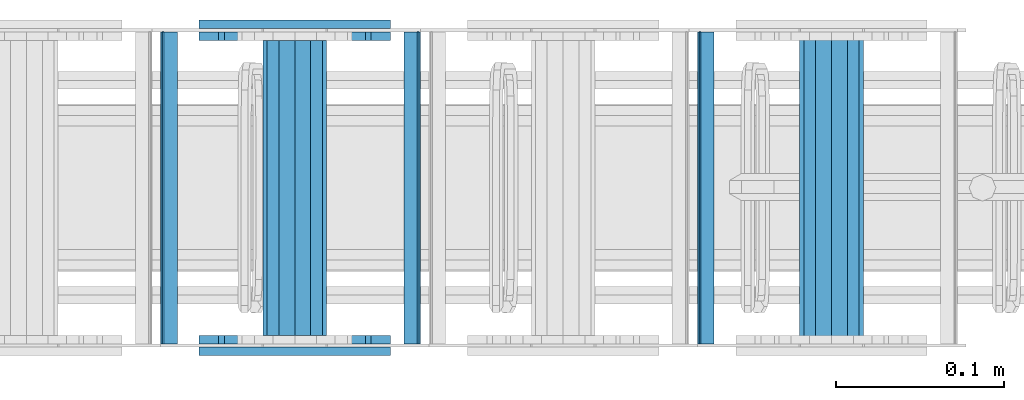
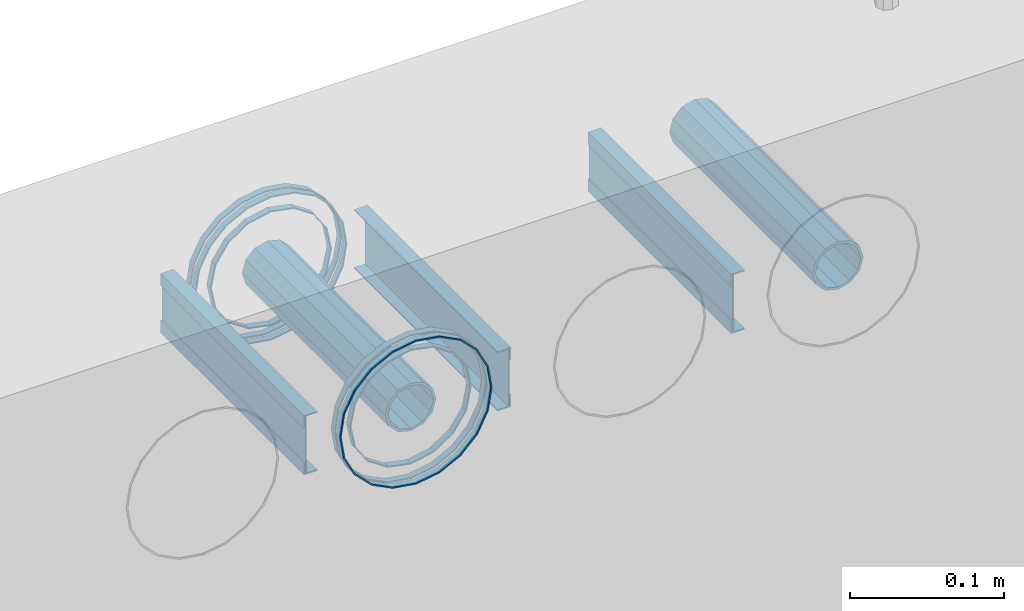
# One storey, part 2 of 11: 17 beams.
"""IFC2X3 building model written with IfcOpenShell, lengths in millimetres."""

import ifcopenshell
import ifcopenshell.guid

model = None  # the IFC model being written
_history = None  # IfcOwnerHistory: only IFC2X3 demands one
_inside = {}  # id of a spatial element -> (the spatial element, [elements in it])
_under = {}  # id of a project, library or spatial element -> (it, [spatial elements below it])
_declared = {}  # id of a project -> (the project, [libraries it declares])
_typed = {}  # id of a type object -> (the type object, [elements of that type])
_made_of = {}  # id of a material, layer set ... -> (it, [elements and type objects made of it])


def new_model(schema):
    """Start an empty IFC model of exactly this schema.

    Asked for "IFC4X3", IfcOpenShell would pick the latest addendum, in which some entities
    have other attributes; the version numbers below select the first issue.
    IFC2X3 requires an IfcOwnerHistory on every rooted entity: one is made here for all.
    """
    global model, _history
    if schema == "IFC4X3":
        model = ifcopenshell.file(schema_version=(4, 3, 0, 0))
    else:
        model = ifcopenshell.file(schema=schema)
    _inside.clear()
    _under.clear()
    _declared.clear()
    _typed.clear()
    _made_of.clear()
    _history = None
    if model.schema == "IFC2X3":
        org = make("IfcOrganization", Name="unknown")
        user = make(
            "IfcPersonAndOrganization",
            ThePerson=make("IfcPerson", FamilyName="unknown"),
            TheOrganization=org,
        )
        app = make(
            "IfcApplication",
            ApplicationDeveloper=org,
            Version="unknown",
            ApplicationFullName="unknown",
            ApplicationIdentifier="unknown",
        )
        _history = make(
            "IfcOwnerHistory",
            OwningUser=user,
            OwningApplication=app,
            ChangeAction="ADDED",
            CreationDate=0,
        )
    return model


def make(cls, **values):
    """One entity of the class cls with the attributes given. An attribute that is None is left unset."""
    return model.create_entity(
        cls, **{name: value for name, value in values.items() if value is not None}
    )


def rooted(cls, **values):
    """An entity with a GlobalId (a new one), such as an element, a storey or a relation."""
    return make(cls, GlobalId=ifcopenshell.guid.new(), OwnerHistory=_history, **values)


def si_unit(unit_type, name, prefix=None):
    """IfcSIUnit, for example si_unit("LENGTHUNIT", "METRE", prefix="MILLI")."""
    return make("IfcSIUnit", UnitType=unit_type, Prefix=prefix, Name=name)


def assignment(units):
    """IfcUnitAssignment: the units of a project."""
    return None if units is None else make("IfcUnitAssignment", Units=units)


def point(xyz):
    """IfcCartesianPoint."""
    return None if xyz is None else make("IfcCartesianPoint", Coordinates=xyz)


def direction(xyz):
    """IfcDirection."""
    return None if xyz is None else make("IfcDirection", DirectionRatios=xyz)


def frame(location, z_axis=None, x_axis=None):
    """IfcAxis2Placement3D, a coordinate frame: its origin and axes. An axis left out is left unset."""
    return make(
        "IfcAxis2Placement3D",
        Location=point(location),
        Axis=direction(z_axis),
        RefDirection=direction(x_axis),
    )


def origin_with_axes():
    """The frame at (0, 0, 0) with the z axis (0, 0, 1) and the x axis (1, 0, 0) written out."""
    return frame((0.0, 0.0, 0.0), z_axis=(0.0, 0.0, 1.0), x_axis=(1.0, 0.0, 0.0))


def place(relative_to, where):
    """IfcLocalPlacement: puts the frame where relative to a parent placement (None: the world)."""
    return make(
        "IfcLocalPlacement", PlacementRelTo=relative_to, RelativePlacement=where
    )


def context(
    kind, dimensions, precision=None, world=None, true_north=None, identifier=None
):
    """IfcGeometricRepresentationContext, for example the 3D "Model" context."""
    return make(
        "IfcGeometricRepresentationContext",
        ContextIdentifier=identifier,
        ContextType=kind,
        CoordinateSpaceDimension=dimensions,
        Precision=precision,
        WorldCoordinateSystem=world,
        TrueNorth=true_north,
    )


def subcontext(parent, identifier, kind, view, scale=None):
    """IfcGeometricRepresentationSubContext, for example "Body" below "Model"."""
    return make(
        "IfcGeometricRepresentationSubContext",
        ContextIdentifier=identifier,
        ContextType=kind,
        ParentContext=parent,
        TargetScale=scale,
        TargetView=view,
    )


def project(units=None, contexts=None):
    """IfcProject with its units and contexts."""
    return rooted(
        "IfcProject",
        Name="project",
        RepresentationContexts=contexts,
        UnitsInContext=assignment(units),
    )


def spatial(cls, under=None, at=None, **own):
    """A site, building, storey or space (cls), placed at a placement, below another one or the project."""
    s = rooted(cls, ObjectPlacement=at, **own)
    if under is not None:
        _under.setdefault(under.id(), (under, []))[1].append(s)
    return s


def faces_of(points, faces, orient=None, outer=None):
    """IfcFace entities. A face is a list of loops; a loop is a list of indices into points, from 0.

    orient and outer hold one flag for each loop. By default every Orientation is true, the
    first loop of a face is its IfcFaceOuterBound and the others are IfcFaceBound.
    """
    made = []
    for i, loops in enumerate(faces):
        bounds = []
        for j, loop in enumerate(loops):
            is_outer = j == 0 if outer is None else outer[i][j]
            bounds.append(
                make(
                    "IfcFaceOuterBound" if is_outer else "IfcFaceBound",
                    Bound=make("IfcPolyLoop", Polygon=[points[k] for k in loop]),
                    Orientation=True if orient is None else orient[i][j],
                )
            )
        made.append(make("IfcFace", Bounds=bounds))
    return made


def faceted_brep(points, faces, orient=None, outer=None, voids=None):
    """IfcFacetedBrep: a solid bounded by flat faces; with voids (closed shells), ...WithVoids."""
    shared = [point(p) for p in points]
    hull = make("IfcClosedShell", CfsFaces=faces_of(shared, faces, orient, outer))
    if voids is None:
        return make("IfcFacetedBrep", Outer=hull)
    return make(
        "IfcFacetedBrepWithVoids",
        Outer=hull,
        Voids=[
            make(cls, CfsFaces=faces_of(shared, fs, o, b)) for cls, fs, o, b in voids
        ],
    )


def shape(context_of_items, identifier, shape_type, items):
    """IfcShapeRepresentation: the items that make up one representation, for example the "Body"."""
    return make(
        "IfcShapeRepresentation",
        ContextOfItems=context_of_items,
        RepresentationIdentifier=identifier,
        RepresentationType=shape_type,
        Items=items,
    )


def material(Name=None, Category=None):
    """IfcMaterial."""
    return make("IfcMaterial", Name=Name, Category=Category)


def made_of(thing, what):
    """Note that an element or type object is made of a material, layer set ...; save() writes the relation."""
    if what is not None:
        _made_of.setdefault(what.id(), (what, []))[1].append(thing)
    return thing


def type_object(cls, material=None, **own):
    """A type object (cls), such as IfcWallType, which elements share."""
    return made_of(rooted(cls, **own), material)


def element(
    cls,
    number,
    at=None,
    inside=None,
    cuts=None,
    type_object=None,
    material=None,
    context=None,
    identifier="Body",
    shape_type=None,
    held_by="IfcProductDefinitionShape",
    body=None,
    shapes=None,
    **own,
):
    """One element of the class cls, such as IfcWall. Its Tag is "e" and its number.

    at: its placement. inside: the storey or other place that contains it. cuts: it is an
    opening in that element (IfcRelVoidsElement). A single representation is given by context,
    identifier, shape_type and body (its items); several are given by shapes. held_by: the class
    of the entity that holds the representations. save() writes the other relations.
    """
    e = rooted(cls, Tag="e%d" % number, ObjectPlacement=at, **own)
    if body is not None:
        shapes = [shape(context, identifier, shape_type, body)]
    if shapes is not None:
        e.Representation = make(held_by, Representations=shapes)
    if inside is not None:
        _inside.setdefault(inside.id(), (inside, []))[1].append(e)
    if cuts is not None:
        rooted(
            "IfcRelVoidsElement", RelatingBuildingElement=cuts, RelatedOpeningElement=e
        )
    if type_object is not None:
        _typed.setdefault(type_object.id(), (type_object, []))[1].append(e)
    return made_of(e, material)


def aggregate(whole, parts):
    """IfcRelAggregates: a whole, such as a stair, and the parts it consists of."""
    return rooted("IfcRelAggregates", RelatingObject=whole, RelatedObjects=parts)


def save(model, path):
    """Write the relations noted so far, then the file.

    IfcRelAggregates (storeys below a building ...), IfcRelContainedInSpatialStructure (elements
    in a storey), IfcRelDefinesByType, IfcRelAssociatesMaterial and IfcRelDeclares: one each for
    every whole, place, type object, material and project.
    """
    for whole, parts in _under.values():
        aggregate(whole, parts)
    for where, things in _inside.values():
        rooted(
            "IfcRelContainedInSpatialStructure",
            RelatedElements=things,
            RelatingStructure=where,
        )
    for kind, things in _typed.values():
        rooted("IfcRelDefinesByType", RelatedObjects=things, RelatingType=kind)
    for what, things in _made_of.values():
        rooted("IfcRelAssociatesMaterial", RelatedObjects=things, RelatingMaterial=what)
    for by, libraries in _declared.values():
        rooted("IfcRelDeclares", RelatingContext=by, RelatedDefinitions=libraries)
    model.write(path)


model = new_model("IFC2X3")

# Units and contexts
model_context = context("Model", 3, precision=1e-05, world=origin_with_axes())
body_context = subcontext(model_context, "Body", "Model", "MODEL_VIEW")
ifc_project = project(units=[si_unit("LENGTHUNIT", "METRE", prefix="MILLI"), si_unit("AREAUNIT", "SQUARE_METRE"), si_unit("VOLUMEUNIT", "CUBIC_METRE"), si_unit("MASSUNIT", "GRAM", prefix="KILO"), si_unit("TIMEUNIT", "SECOND"), si_unit("PLANEANGLEUNIT", "RADIAN"), si_unit("SOLIDANGLEUNIT", "STERADIAN"), si_unit("THERMODYNAMICTEMPERATUREUNIT", "DEGREE_CELSIUS"), si_unit("LUMINOUSINTENSITYUNIT", "LUMEN")], contexts=[model_context])

# Site, building, storey
site_placement = place(None, origin_with_axes())
site = spatial("IfcSite", under=ifc_project, at=site_placement, CompositionType="ELEMENT")
building_placement = place(site_placement, origin_with_axes())
building = spatial("IfcBuilding", under=site, at=building_placement, Name="Undefined", CompositionType="ELEMENT")
storey_placement = place(building_placement, origin_with_axes())
storey = spatial("IfcBuildingStorey", under=building, at=storey_placement, Name="Undefined", CompositionType="ELEMENT", Elevation=0.0)

# Beams
ifc_material = material(Name="STEEL/Steel_Undefined")
beam_type_1 = type_object("IfcBeamType", PredefinedType="NOTDEFINED")
beam_1_placement = place(storey_placement, frame((1659.98457749309, -5.08317012009302, 2335.01381840039), z_axis=(-1.0, 0.0, 0.0), x_axis=(0.0, 1.0, 0.0)))
element("IfcBeam", 1, at=beam_1_placement, inside=storey, type_object=beam_type_1, material=ifc_material, Name="K160", context=body_context, shape_type="Brep", body=[
    faceted_brep([(0.0, -56.0, 0.0), (0.0, -53.2591649125284, 17.3049516849972), (5.0, -53.2591649125284, 17.3049516849972), (5.0, -56.0, 0.0), (0.0, -45.3049516849969, 32.9159741283786), (5.0, -45.3049516849969, 32.9159741283786), (0.0, -32.9159741283784, 45.3049516849972), (5.0, -32.9159741283784, 45.3049516849972), (0.0, -17.3049516849969, 53.2591649125286), (5.0, -17.3049516849969, 53.2591649125286), (0.0, 0.0, 56.0), (5.0, 0.0, 56.0), (0.0, 17.3049516849969, 53.2591649125286), (5.0, 17.3049516849969, 53.2591649125286), (0.0, 32.9159741283784, 45.3049516849972), (5.0, 32.9159741283784, 45.3049516849972), (0.0, 45.3049516849969, 32.9159741283786), (5.0, 45.3049516849969, 32.9159741283786), (0.0, 53.2591649125284, 17.3049516849972), (5.0, 53.2591649125284, 17.3049516849972), (0.0, 56.0, 0.0), (5.0, 56.0, 0.0), (0.0, 53.2591649125284, -17.3049516849972), (5.0, 53.2591649125284, -17.3049516849972), (0.0, 45.3049516849969, -32.9159741283786), (5.0, 45.3049516849969, -32.9159741283786), (0.0, 32.9159741283784, -45.3049516849972), (5.0, 32.9159741283784, -45.3049516849972), (0.0, 17.3049516849969, -53.2591649125286), (5.0, 17.3049516849969, -53.2591649125286), (0.0, 0.0, -56.0), (5.0, 0.0, -56.0), (0.0, -17.3049516849969, -53.2591649125286), (5.0, -17.3049516849969, -53.2591649125286), (0.0, -32.9159741283784, -45.3049516849972), (5.0, -32.9159741283784, -45.3049516849972), (0.0, -45.3049516849969, -32.9159741283786), (5.0, -45.3049516849969, -32.9159741283786), (0.0, -53.2591649125284, -17.3049516849972), (5.0, -53.2591649125284, -17.3049516849972), (0.0, -57.0, 0.0), (0.0, -54.2102214288238, -17.613968679372), (5.0, -54.2102214288238, -17.613968679372), (5.0, -57.0, 0.0), (0.0, -46.1139686793722, -33.503759380671), (5.0, -46.1139686793722, -33.503759380671), (0.0, -33.503759380671, -46.113968679372), (5.0, -33.503759380671, -46.113968679372), (0.0, -17.6139686793722, -54.2102214288238), (5.0, -17.6139686793722, -54.2102214288238), (0.0, 0.0, -57.0), (5.0, 0.0, -57.0), (0.0, 17.6139686793722, -54.2102214288238), (5.0, 17.6139686793722, -54.2102214288238), (0.0, 33.503759380671, -46.113968679372), (5.0, 33.503759380671, -46.113968679372), (0.0, 46.1139686793722, -33.503759380671), (5.0, 46.1139686793722, -33.503759380671), (0.0, 54.2102214288238, -17.613968679372), (5.0, 54.2102214288238, -17.613968679372), (0.0, 57.0, 0.0), (5.0, 57.0, 0.0), (0.0, 54.2102214288238, 17.613968679372), (5.0, 54.2102214288238, 17.613968679372), (0.0, 46.1139686793722, 33.503759380671), (5.0, 46.1139686793722, 33.503759380671), (0.0, 33.503759380671, 46.113968679372), (5.0, 33.503759380671, 46.113968679372), (0.0, 17.6139686793722, 54.2102214288238), (5.0, 17.6139686793722, 54.2102214288238), (0.0, 0.0, 57.0), (5.0, 0.0, 57.0), (0.0, -17.6139686793722, 54.2102214288238), (5.0, -17.6139686793722, 54.2102214288238), (0.0, -33.503759380671, 46.113968679372), (5.0, -33.503759380671, 46.113968679372), (0.0, -46.1139686793722, 33.503759380671), (5.0, -46.1139686793722, 33.503759380671), (0.0, -54.2102214288238, 17.613968679372), (5.0, -54.2102214288238, 17.613968679372)], [[[0, 1, 2, 3]], [[1, 4, 5, 2]], [[4, 6, 7, 5]], [[6, 8, 9, 7]], [[8, 10, 11, 9]], [[10, 12, 13, 11]], [[12, 14, 15, 13]], [[14, 16, 17, 15]], [[16, 18, 19, 17]], [[18, 20, 21, 19]], [[20, 22, 23, 21]], [[22, 24, 25, 23]], [[24, 26, 27, 25]], [[26, 28, 29, 27]], [[28, 30, 31, 29]], [[30, 32, 33, 31]], [[32, 34, 35, 33]], [[34, 36, 37, 35]], [[36, 38, 39, 37]], [[38, 0, 3, 39]], [[40, 41, 42, 43]], [[41, 44, 45, 42]], [[44, 46, 47, 45]], [[46, 48, 49, 47]], [[48, 50, 51, 49]], [[50, 52, 53, 51]], [[52, 54, 55, 53]], [[54, 56, 57, 55]], [[56, 58, 59, 57]], [[58, 60, 61, 59]], [[60, 62, 63, 61]], [[62, 64, 65, 63]], [[64, 66, 67, 65]], [[66, 68, 69, 67]], [[68, 70, 71, 69]], [[70, 72, 73, 71]], [[72, 74, 75, 73]], [[74, 76, 77, 75]], [[76, 78, 79, 77]], [[78, 40, 43, 79]], [[45, 47, 49, 51, 53, 55, 57, 59, 61, 63, 65, 67, 69, 71, 73, 75, 77, 79, 43, 42], [5, 7, 9, 11, 13, 15, 17, 19, 21, 23, 25, 27, 29, 31, 33, 35, 37, 39, 3, 2]], [[78, 76, 74, 72, 70, 68, 66, 64, 62, 60, 58, 56, 54, 52, 50, 48, 46, 44, 41, 40], [38, 36, 34, 32, 30, 28, 26, 24, 22, 20, 18, 16, 14, 12, 10, 8, 6, 4, 1, 0]]]),
])
beam_2_placement = place(storey_placement, frame((1659.98457749309, -200.083170120093, 2335.01381840039), z_axis=(-1.0, 0.0, 0.0), x_axis=(0.0, 1.0, 0.0)))
element("IfcBeam", 2, at=beam_2_placement, inside=storey, type_object=beam_type_1, material=ifc_material, context=body_context, shape_type="Brep", body=[
    faceted_brep([(0.0, -56.0, 0.0), (0.0, -53.2591649125284, 17.3049516849972), (5.0, -53.2591649125284, 17.3049516849972), (5.0, -56.0, 0.0), (0.0, -45.3049516849969, 32.9159741283786), (5.0, -45.3049516849969, 32.9159741283786), (0.0, -32.9159741283784, 45.3049516849972), (5.0, -32.9159741283784, 45.3049516849972), (0.0, -17.3049516849969, 53.2591649125286), (5.0, -17.3049516849969, 53.2591649125286), (0.0, 0.0, 56.0), (5.0, 0.0, 56.0), (0.0, 17.3049516849969, 53.2591649125286), (5.0, 17.3049516849969, 53.2591649125286), (0.0, 32.9159741283784, 45.3049516849972), (5.0, 32.9159741283784, 45.3049516849972), (0.0, 45.3049516849969, 32.9159741283786), (5.0, 45.3049516849969, 32.9159741283786), (0.0, 53.2591649125284, 17.3049516849972), (5.0, 53.2591649125284, 17.3049516849972), (0.0, 56.0, 0.0), (5.0, 56.0, 0.0), (0.0, 53.2591649125284, -17.3049516849972), (5.0, 53.2591649125284, -17.3049516849972), (0.0, 45.3049516849969, -32.9159741283786), (5.0, 45.3049516849969, -32.9159741283786), (0.0, 32.9159741283784, -45.3049516849972), (5.0, 32.9159741283784, -45.3049516849972), (0.0, 17.3049516849969, -53.2591649125286), (5.0, 17.3049516849969, -53.2591649125286), (0.0, 0.0, -56.0), (5.0, 0.0, -56.0), (0.0, -17.3049516849969, -53.2591649125286), (5.0, -17.3049516849969, -53.2591649125286), (0.0, -32.9159741283784, -45.3049516849972), (5.0, -32.9159741283784, -45.3049516849972), (0.0, -45.3049516849969, -32.9159741283786), (5.0, -45.3049516849969, -32.9159741283786), (0.0, -53.2591649125284, -17.3049516849972), (5.0, -53.2591649125284, -17.3049516849972), (0.0, -57.0, 0.0), (0.0, -54.2102214288238, -17.613968679372), (5.0, -54.2102214288238, -17.613968679372), (5.0, -57.0, 0.0), (0.0, -46.1139686793722, -33.503759380671), (5.0, -46.1139686793722, -33.503759380671), (0.0, -33.503759380671, -46.113968679372), (5.0, -33.503759380671, -46.113968679372), (0.0, -17.6139686793722, -54.2102214288238), (5.0, -17.6139686793722, -54.2102214288238), (0.0, 0.0, -57.0), (5.0, 0.0, -57.0), (0.0, 17.6139686793722, -54.2102214288238), (5.0, 17.6139686793722, -54.2102214288238), (0.0, 33.503759380671, -46.113968679372), (5.0, 33.503759380671, -46.113968679372), (0.0, 46.1139686793722, -33.503759380671), (5.0, 46.1139686793722, -33.503759380671), (0.0, 54.2102214288238, -17.613968679372), (5.0, 54.2102214288238, -17.613968679372), (0.0, 57.0, 0.0), (5.0, 57.0, 0.0), (0.0, 54.2102214288238, 17.613968679372), (5.0, 54.2102214288238, 17.613968679372), (0.0, 46.1139686793722, 33.503759380671), (5.0, 46.1139686793722, 33.503759380671), (0.0, 33.503759380671, 46.113968679372), (5.0, 33.503759380671, 46.113968679372), (0.0, 17.6139686793722, 54.2102214288238), (5.0, 17.6139686793722, 54.2102214288238), (0.0, 0.0, 57.0), (5.0, 0.0, 57.0), (0.0, -17.6139686793722, 54.2102214288238), (5.0, -17.6139686793722, 54.2102214288238), (0.0, -33.503759380671, 46.113968679372), (5.0, -33.503759380671, 46.113968679372), (0.0, -46.1139686793722, 33.503759380671), (5.0, -46.1139686793722, 33.503759380671), (0.0, -54.2102214288238, 17.613968679372), (5.0, -54.2102214288238, 17.613968679372)], [[[0, 1, 2, 3]], [[1, 4, 5, 2]], [[4, 6, 7, 5]], [[6, 8, 9, 7]], [[8, 10, 11, 9]], [[10, 12, 13, 11]], [[12, 14, 15, 13]], [[14, 16, 17, 15]], [[16, 18, 19, 17]], [[18, 20, 21, 19]], [[20, 22, 23, 21]], [[22, 24, 25, 23]], [[24, 26, 27, 25]], [[26, 28, 29, 27]], [[28, 30, 31, 29]], [[30, 32, 33, 31]], [[32, 34, 35, 33]], [[34, 36, 37, 35]], [[36, 38, 39, 37]], [[38, 0, 3, 39]], [[40, 41, 42, 43]], [[41, 44, 45, 42]], [[44, 46, 47, 45]], [[46, 48, 49, 47]], [[48, 50, 51, 49]], [[50, 52, 53, 51]], [[52, 54, 55, 53]], [[54, 56, 57, 55]], [[56, 58, 59, 57]], [[58, 60, 61, 59]], [[60, 62, 63, 61]], [[62, 64, 65, 63]], [[64, 66, 67, 65]], [[66, 68, 69, 67]], [[68, 70, 71, 69]], [[70, 72, 73, 71]], [[72, 74, 75, 73]], [[74, 76, 77, 75]], [[76, 78, 79, 77]], [[78, 40, 43, 79]], [[45, 47, 49, 51, 53, 55, 57, 59, 61, 63, 65, 67, 69, 71, 73, 75, 77, 79, 43, 42], [5, 7, 9, 11, 13, 15, 17, 19, 21, 23, 25, 27, 29, 31, 33, 35, 37, 39, 3, 2]], [[78, 76, 74, 72, 70, 68, 66, 64, 62, 60, 58, 56, 54, 52, 50, 48, 46, 44, 41, 40], [38, 36, 34, 32, 30, 28, 26, 24, 22, 20, 18, 16, 14, 12, 10, 8, 6, 4, 1, 0]]]),
])
beam_3_placement = place(storey_placement, frame((1659.98457749309, -12.083170120093, 2335.01381840039), z_axis=(-1.0, 0.0, 0.0), x_axis=(0.0, 1.0, 0.0)))
element("IfcBeam", 3, at=beam_3_placement, inside=storey, type_object=beam_type_1, material=ifc_material, context=body_context, shape_type="Brep", body=[
    faceted_brep([(0.0, -56.0, 0.0), (0.0, -53.2591649125284, 17.3049516849972), (5.0, -53.2591649125284, 17.3049516849972), (5.0, -56.0, 0.0), (0.0, -45.3049516849969, 32.9159741283786), (5.0, -45.3049516849969, 32.9159741283786), (0.0, -32.9159741283784, 45.3049516849972), (5.0, -32.9159741283784, 45.3049516849972), (0.0, -17.3049516849969, 53.2591649125286), (5.0, -17.3049516849969, 53.2591649125286), (0.0, 0.0, 56.0), (5.0, 0.0, 56.0), (0.0, 17.3049516849969, 53.2591649125286), (5.0, 17.3049516849969, 53.2591649125286), (0.0, 32.9159741283784, 45.3049516849972), (5.0, 32.9159741283784, 45.3049516849972), (0.0, 45.3049516849969, 32.9159741283786), (5.0, 45.3049516849969, 32.9159741283786), (0.0, 53.2591649125284, 17.3049516849972), (5.0, 53.2591649125284, 17.3049516849972), (0.0, 56.0, 0.0), (5.0, 56.0, 0.0), (0.0, 53.2591649125284, -17.3049516849972), (5.0, 53.2591649125284, -17.3049516849972), (0.0, 45.3049516849969, -32.9159741283786), (5.0, 45.3049516849969, -32.9159741283786), (0.0, 32.9159741283784, -45.3049516849972), (5.0, 32.9159741283784, -45.3049516849972), (0.0, 17.3049516849969, -53.2591649125286), (5.0, 17.3049516849969, -53.2591649125286), (0.0, 0.0, -56.0), (5.0, 0.0, -56.0), (0.0, -17.3049516849969, -53.2591649125286), (5.0, -17.3049516849969, -53.2591649125286), (0.0, -32.9159741283784, -45.3049516849972), (5.0, -32.9159741283784, -45.3049516849972), (0.0, -45.3049516849969, -32.9159741283786), (5.0, -45.3049516849969, -32.9159741283786), (0.0, -53.2591649125284, -17.3049516849972), (5.0, -53.2591649125284, -17.3049516849972), (0.0, -57.0, 0.0), (0.0, -54.2102214288238, -17.613968679372), (5.0, -54.2102214288238, -17.613968679372), (5.0, -57.0, 0.0), (0.0, -46.1139686793722, -33.503759380671), (5.0, -46.1139686793722, -33.503759380671), (0.0, -33.503759380671, -46.113968679372), (5.0, -33.503759380671, -46.113968679372), (0.0, -17.6139686793722, -54.2102214288238), (5.0, -17.6139686793722, -54.2102214288238), (0.0, 0.0, -57.0), (5.0, 0.0, -57.0), (0.0, 17.6139686793722, -54.2102214288238), (5.0, 17.6139686793722, -54.2102214288238), (0.0, 33.503759380671, -46.113968679372), (5.0, 33.503759380671, -46.113968679372), (0.0, 46.1139686793722, -33.503759380671), (5.0, 46.1139686793722, -33.503759380671), (0.0, 54.2102214288238, -17.613968679372), (5.0, 54.2102214288238, -17.613968679372), (0.0, 57.0, 0.0), (5.0, 57.0, 0.0), (0.0, 54.2102214288238, 17.613968679372), (5.0, 54.2102214288238, 17.613968679372), (0.0, 46.1139686793722, 33.503759380671), (5.0, 46.1139686793722, 33.503759380671), (0.0, 33.503759380671, 46.113968679372), (5.0, 33.503759380671, 46.113968679372), (0.0, 17.6139686793722, 54.2102214288238), (5.0, 17.6139686793722, 54.2102214288238), (0.0, 0.0, 57.0), (5.0, 0.0, 57.0), (0.0, -17.6139686793722, 54.2102214288238), (5.0, -17.6139686793722, 54.2102214288238), (0.0, -33.503759380671, 46.113968679372), (5.0, -33.503759380671, 46.113968679372), (0.0, -46.1139686793722, 33.503759380671), (5.0, -46.1139686793722, 33.503759380671), (0.0, -54.2102214288238, 17.613968679372), (5.0, -54.2102214288238, 17.613968679372)], [[[0, 1, 2, 3]], [[1, 4, 5, 2]], [[4, 6, 7, 5]], [[6, 8, 9, 7]], [[8, 10, 11, 9]], [[10, 12, 13, 11]], [[12, 14, 15, 13]], [[14, 16, 17, 15]], [[16, 18, 19, 17]], [[18, 20, 21, 19]], [[20, 22, 23, 21]], [[22, 24, 25, 23]], [[24, 26, 27, 25]], [[26, 28, 29, 27]], [[28, 30, 31, 29]], [[30, 32, 33, 31]], [[32, 34, 35, 33]], [[34, 36, 37, 35]], [[36, 38, 39, 37]], [[38, 0, 3, 39]], [[40, 41, 42, 43]], [[41, 44, 45, 42]], [[44, 46, 47, 45]], [[46, 48, 49, 47]], [[48, 50, 51, 49]], [[50, 52, 53, 51]], [[52, 54, 55, 53]], [[54, 56, 57, 55]], [[56, 58, 59, 57]], [[58, 60, 61, 59]], [[60, 62, 63, 61]], [[62, 64, 65, 63]], [[64, 66, 67, 65]], [[66, 68, 69, 67]], [[68, 70, 71, 69]], [[70, 72, 73, 71]], [[72, 74, 75, 73]], [[74, 76, 77, 75]], [[76, 78, 79, 77]], [[78, 40, 43, 79]], [[45, 47, 49, 51, 53, 55, 57, 59, 61, 63, 65, 67, 69, 71, 73, 75, 77, 79, 43, 42], [5, 7, 9, 11, 13, 15, 17, 19, 21, 23, 25, 27, 29, 31, 33, 35, 37, 39, 3, 2]], [[78, 76, 74, 72, 70, 68, 66, 64, 62, 60, 58, 56, 54, 52, 50, 48, 46, 44, 41, 40], [38, 36, 34, 32, 30, 28, 26, 24, 22, 20, 18, 16, 14, 12, 10, 8, 6, 4, 1, 0]]]),
])
beam_4_placement = place(storey_placement, frame((1659.98457749309, -188.083170120093, 2335.01381840039), z_axis=(-1.0, 0.0, 0.0), x_axis=(0.0, -1.0, 0.0)))
element("IfcBeam", 4, at=beam_4_placement, inside=storey, type_object=beam_type_1, material=ifc_material, context=body_context, shape_type="Brep", body=[
    faceted_brep([(0.0, -56.0, 0.0), (0.0, -53.2591649125284, 17.3049516849972), (5.0, -53.2591649125284, 17.3049516849972), (5.0, -56.0, 0.0), (0.0, -45.3049516849969, 32.9159741283786), (5.0, -45.3049516849969, 32.9159741283786), (0.0, -32.9159741283784, 45.3049516849972), (5.0, -32.9159741283784, 45.3049516849972), (0.0, -17.3049516849969, 53.2591649125286), (5.0, -17.3049516849969, 53.2591649125286), (0.0, 0.0, 56.0), (5.0, 0.0, 56.0), (0.0, 17.3049516849969, 53.2591649125286), (5.0, 17.3049516849969, 53.2591649125286), (0.0, 32.9159741283784, 45.3049516849972), (5.0, 32.9159741283784, 45.3049516849972), (0.0, 45.3049516849969, 32.9159741283786), (5.0, 45.3049516849969, 32.9159741283786), (0.0, 53.2591649125284, 17.3049516849972), (5.0, 53.2591649125284, 17.3049516849972), (0.0, 56.0, 0.0), (5.0, 56.0, 0.0), (0.0, 53.2591649125284, -17.3049516849972), (5.0, 53.2591649125284, -17.3049516849972), (0.0, 45.3049516849969, -32.9159741283786), (5.0, 45.3049516849969, -32.9159741283786), (0.0, 32.9159741283784, -45.3049516849972), (5.0, 32.9159741283784, -45.3049516849972), (0.0, 17.3049516849969, -53.2591649125286), (5.0, 17.3049516849969, -53.2591649125286), (0.0, 0.0, -56.0), (5.0, 0.0, -56.0), (0.0, -17.3049516849969, -53.2591649125286), (5.0, -17.3049516849969, -53.2591649125286), (0.0, -32.9159741283784, -45.3049516849972), (5.0, -32.9159741283784, -45.3049516849972), (0.0, -45.3049516849969, -32.9159741283786), (5.0, -45.3049516849969, -32.9159741283786), (0.0, -53.2591649125284, -17.3049516849972), (5.0, -53.2591649125284, -17.3049516849972), (0.0, -57.0, 0.0), (0.0, -54.2102214288238, -17.613968679372), (5.0, -54.2102214288238, -17.613968679372), (5.0, -57.0, 0.0), (0.0, -46.1139686793722, -33.503759380671), (5.0, -46.1139686793722, -33.503759380671), (0.0, -33.503759380671, -46.113968679372), (5.0, -33.503759380671, -46.113968679372), (0.0, -17.6139686793722, -54.2102214288238), (5.0, -17.6139686793722, -54.2102214288238), (0.0, 0.0, -57.0), (5.0, 0.0, -57.0), (0.0, 17.6139686793722, -54.2102214288238), (5.0, 17.6139686793722, -54.2102214288238), (0.0, 33.503759380671, -46.113968679372), (5.0, 33.503759380671, -46.113968679372), (0.0, 46.1139686793722, -33.503759380671), (5.0, 46.1139686793722, -33.503759380671), (0.0, 54.2102214288238, -17.613968679372), (5.0, 54.2102214288238, -17.613968679372), (0.0, 57.0, 0.0), (5.0, 57.0, 0.0), (0.0, 54.2102214288238, 17.613968679372), (5.0, 54.2102214288238, 17.613968679372), (0.0, 46.1139686793722, 33.503759380671), (5.0, 46.1139686793722, 33.503759380671), (0.0, 33.503759380671, 46.113968679372), (5.0, 33.503759380671, 46.113968679372), (0.0, 17.6139686793722, 54.2102214288238), (5.0, 17.6139686793722, 54.2102214288238), (0.0, 0.0, 57.0), (5.0, 0.0, 57.0), (0.0, -17.6139686793722, 54.2102214288238), (5.0, -17.6139686793722, 54.2102214288238), (0.0, -33.503759380671, 46.113968679372), (5.0, -33.503759380671, 46.113968679372), (0.0, -46.1139686793722, 33.503759380671), (5.0, -46.1139686793722, 33.503759380671), (0.0, -54.2102214288238, 17.613968679372), (5.0, -54.2102214288238, 17.613968679372)], [[[0, 1, 2, 3]], [[1, 4, 5, 2]], [[4, 6, 7, 5]], [[6, 8, 9, 7]], [[8, 10, 11, 9]], [[10, 12, 13, 11]], [[12, 14, 15, 13]], [[14, 16, 17, 15]], [[16, 18, 19, 17]], [[18, 20, 21, 19]], [[20, 22, 23, 21]], [[22, 24, 25, 23]], [[24, 26, 27, 25]], [[26, 28, 29, 27]], [[28, 30, 31, 29]], [[30, 32, 33, 31]], [[32, 34, 35, 33]], [[34, 36, 37, 35]], [[36, 38, 39, 37]], [[38, 0, 3, 39]], [[40, 41, 42, 43]], [[41, 44, 45, 42]], [[44, 46, 47, 45]], [[46, 48, 49, 47]], [[48, 50, 51, 49]], [[50, 52, 53, 51]], [[52, 54, 55, 53]], [[54, 56, 57, 55]], [[56, 58, 59, 57]], [[58, 60, 61, 59]], [[60, 62, 63, 61]], [[62, 64, 65, 63]], [[64, 66, 67, 65]], [[66, 68, 69, 67]], [[68, 70, 71, 69]], [[70, 72, 73, 71]], [[72, 74, 75, 73]], [[74, 76, 77, 75]], [[76, 78, 79, 77]], [[78, 40, 43, 79]], [[45, 47, 49, 51, 53, 55, 57, 59, 61, 63, 65, 67, 69, 71, 73, 75, 77, 79, 43, 42], [5, 7, 9, 11, 13, 15, 17, 19, 21, 23, 25, 27, 29, 31, 33, 35, 37, 39, 3, 2]], [[78, 76, 74, 72, 70, 68, 66, 64, 62, 60, 58, 56, 54, 52, 50, 48, 46, 44, 41, 40], [38, 36, 34, 32, 30, 28, 26, 24, 22, 20, 18, 16, 14, 12, 10, 8, 6, 4, 1, 0]]]),
])
beam_type_2 = type_object("IfcBeamType", PredefinedType="NOTDEFINED")
beam_5_placement = place(storey_placement, frame((1659.98457749309, -12.083170120093, 2335.01381840039), z_axis=(-1.0, 0.0, 0.0), x_axis=(0.0, 1.0, 0.0)))
element("IfcBeam", 5, at=beam_5_placement, inside=storey, type_object=beam_type_2, material=ifc_material, context=body_context, shape_type="Brep", body=[
    faceted_brep([(0.0, -44.5, 0.0), (0.0, -41.1126391967523, 17.0294127402465), (5.0, -41.1126391967523, 17.0294127402465), (5.0, -44.5, 0.0), (0.0, -31.4662517628012, 31.4662517628014), (5.0, -31.4662517628012, 31.4662517628014), (0.0, -17.0294127402467, 41.1126391967523), (5.0, -17.0294127402467, 41.1126391967523), (0.0, 0.0, 44.5), (5.0, 0.0, 44.5), (0.0, 17.0294127402467, 41.1126391967523), (5.0, 17.0294127402467, 41.1126391967523), (0.0, 31.4662517628012, 31.4662517628014), (5.0, 31.4662517628012, 31.4662517628014), (0.0, 41.1126391967523, 17.0294127402465), (5.0, 41.1126391967523, 17.0294127402465), (0.0, 44.5, 0.0), (5.0, 44.5, 0.0), (0.0, 41.1126391967523, -17.0294127402465), (5.0, 41.1126391967523, -17.0294127402465), (0.0, 31.4662517628012, -31.4662517628014), (5.0, 31.4662517628012, -31.4662517628014), (0.0, 17.0294127402467, -41.1126391967523), (5.0, 17.0294127402467, -41.1126391967523), (0.0, 0.0, -44.5), (5.0, 0.0, -44.5), (0.0, -17.0294127402467, -41.1126391967523), (5.0, -17.0294127402467, -41.1126391967523), (0.0, -31.4662517628012, -31.4662517628014), (5.0, -31.4662517628012, -31.4662517628014), (0.0, -41.1126391967523, -17.0294127402465), (5.0, -41.1126391967523, -17.0294127402465), (0.0, -45.5, 0.0), (0.0, -42.0365187292637, -17.4120961726117), (5.0, -42.0365187292637, -17.4120961726117), (5.0, -45.5, 0.0), (0.0, -32.1733585439879, -32.1733585439879), (5.0, -32.1733585439879, -32.1733585439879), (0.0, -17.4120961726117, -42.0365187292634), (5.0, -17.4120961726117, -42.0365187292634), (0.0, 0.0, -45.5), (5.0, 0.0, -45.5), (0.0, 17.4120961726117, -42.0365187292634), (5.0, 17.4120961726117, -42.0365187292634), (0.0, 32.1733585439879, -32.1733585439879), (5.0, 32.1733585439879, -32.1733585439879), (0.0, 42.0365187292637, -17.4120961726117), (5.0, 42.0365187292637, -17.4120961726117), (0.0, 45.5, 0.0), (5.0, 45.5, 0.0), (0.0, 42.0365187292637, 17.4120961726117), (5.0, 42.0365187292637, 17.4120961726117), (0.0, 32.1733585439879, 32.1733585439879), (5.0, 32.1733585439879, 32.1733585439879), (0.0, 17.4120961726117, 42.0365187292634), (5.0, 17.4120961726117, 42.0365187292634), (0.0, 0.0, 45.5), (5.0, 0.0, 45.5), (0.0, -17.4120961726117, 42.0365187292634), (5.0, -17.4120961726117, 42.0365187292634), (0.0, -32.1733585439879, 32.1733585439879), (5.0, -32.1733585439879, 32.1733585439879), (0.0, -42.0365187292637, 17.4120961726117), (5.0, -42.0365187292637, 17.4120961726117)], [[[0, 1, 2, 3]], [[1, 4, 5, 2]], [[4, 6, 7, 5]], [[6, 8, 9, 7]], [[8, 10, 11, 9]], [[10, 12, 13, 11]], [[12, 14, 15, 13]], [[14, 16, 17, 15]], [[16, 18, 19, 17]], [[18, 20, 21, 19]], [[20, 22, 23, 21]], [[22, 24, 25, 23]], [[24, 26, 27, 25]], [[26, 28, 29, 27]], [[28, 30, 31, 29]], [[30, 0, 3, 31]], [[32, 33, 34, 35]], [[33, 36, 37, 34]], [[36, 38, 39, 37]], [[38, 40, 41, 39]], [[40, 42, 43, 41]], [[42, 44, 45, 43]], [[44, 46, 47, 45]], [[46, 48, 49, 47]], [[48, 50, 51, 49]], [[50, 52, 53, 51]], [[52, 54, 55, 53]], [[54, 56, 57, 55]], [[56, 58, 59, 57]], [[58, 60, 61, 59]], [[60, 62, 63, 61]], [[62, 32, 35, 63]], [[37, 39, 41, 43, 45, 47, 49, 51, 53, 55, 57, 59, 61, 63, 35, 34], [5, 7, 9, 11, 13, 15, 17, 19, 21, 23, 25, 27, 29, 31, 3, 2]], [[62, 60, 58, 56, 54, 52, 50, 48, 46, 44, 42, 40, 38, 36, 33, 32], [30, 28, 26, 24, 22, 20, 18, 16, 14, 12, 10, 8, 6, 4, 1, 0]]]),
])
beam_6_placement = place(storey_placement, frame((1659.98457749309, -188.083170120093, 2335.01381840039), z_axis=(-1.0, 0.0, 0.0), x_axis=(0.0, -1.0, 0.0)))
element("IfcBeam", 6, at=beam_6_placement, inside=storey, type_object=beam_type_2, material=ifc_material, context=body_context, shape_type="Brep", body=[
    faceted_brep([(0.0, -44.5, 0.0), (0.0, -41.1126391967523, 17.0294127402465), (5.0, -41.1126391967523, 17.0294127402465), (5.0, -44.5, 0.0), (0.0, -31.4662517628012, 31.4662517628014), (5.0, -31.4662517628012, 31.4662517628014), (0.0, -17.0294127402467, 41.1126391967523), (5.0, -17.0294127402467, 41.1126391967523), (0.0, 0.0, 44.5), (5.0, 0.0, 44.5), (0.0, 17.0294127402467, 41.1126391967523), (5.0, 17.0294127402467, 41.1126391967523), (0.0, 31.4662517628012, 31.4662517628014), (5.0, 31.4662517628012, 31.4662517628014), (0.0, 41.1126391967523, 17.0294127402465), (5.0, 41.1126391967523, 17.0294127402465), (0.0, 44.5, 0.0), (5.0, 44.5, 0.0), (0.0, 41.1126391967523, -17.0294127402465), (5.0, 41.1126391967523, -17.0294127402465), (0.0, 31.4662517628012, -31.4662517628014), (5.0, 31.4662517628012, -31.4662517628014), (0.0, 17.0294127402467, -41.1126391967523), (5.0, 17.0294127402467, -41.1126391967523), (0.0, 0.0, -44.5), (5.0, 0.0, -44.5), (0.0, -17.0294127402467, -41.1126391967523), (5.0, -17.0294127402467, -41.1126391967523), (0.0, -31.4662517628012, -31.4662517628014), (5.0, -31.4662517628012, -31.4662517628014), (0.0, -41.1126391967523, -17.0294127402465), (5.0, -41.1126391967523, -17.0294127402465), (0.0, -45.5, 0.0), (0.0, -42.0365187292637, -17.4120961726117), (5.0, -42.0365187292637, -17.4120961726117), (5.0, -45.5, 0.0), (0.0, -32.1733585439879, -32.1733585439879), (5.0, -32.1733585439879, -32.1733585439879), (0.0, -17.4120961726117, -42.0365187292634), (5.0, -17.4120961726117, -42.0365187292634), (0.0, 0.0, -45.5), (5.0, 0.0, -45.5), (0.0, 17.4120961726117, -42.0365187292634), (5.0, 17.4120961726117, -42.0365187292634), (0.0, 32.1733585439879, -32.1733585439879), (5.0, 32.1733585439879, -32.1733585439879), (0.0, 42.0365187292637, -17.4120961726117), (5.0, 42.0365187292637, -17.4120961726117), (0.0, 45.5, 0.0), (5.0, 45.5, 0.0), (0.0, 42.0365187292637, 17.4120961726117), (5.0, 42.0365187292637, 17.4120961726117), (0.0, 32.1733585439879, 32.1733585439879), (5.0, 32.1733585439879, 32.1733585439879), (0.0, 17.4120961726117, 42.0365187292634), (5.0, 17.4120961726117, 42.0365187292634), (0.0, 0.0, 45.5), (5.0, 0.0, 45.5), (0.0, -17.4120961726117, 42.0365187292634), (5.0, -17.4120961726117, 42.0365187292634), (0.0, -32.1733585439879, 32.1733585439879), (5.0, -32.1733585439879, 32.1733585439879), (0.0, -42.0365187292637, 17.4120961726117), (5.0, -42.0365187292637, 17.4120961726117)], [[[0, 1, 2, 3]], [[1, 4, 5, 2]], [[4, 6, 7, 5]], [[6, 8, 9, 7]], [[8, 10, 11, 9]], [[10, 12, 13, 11]], [[12, 14, 15, 13]], [[14, 16, 17, 15]], [[16, 18, 19, 17]], [[18, 20, 21, 19]], [[20, 22, 23, 21]], [[22, 24, 25, 23]], [[24, 26, 27, 25]], [[26, 28, 29, 27]], [[28, 30, 31, 29]], [[30, 0, 3, 31]], [[32, 33, 34, 35]], [[33, 36, 37, 34]], [[36, 38, 39, 37]], [[38, 40, 41, 39]], [[40, 42, 43, 41]], [[42, 44, 45, 43]], [[44, 46, 47, 45]], [[46, 48, 49, 47]], [[48, 50, 51, 49]], [[50, 52, 53, 51]], [[52, 54, 55, 53]], [[54, 56, 57, 55]], [[56, 58, 59, 57]], [[58, 60, 61, 59]], [[60, 62, 63, 61]], [[62, 32, 35, 63]], [[37, 39, 41, 43, 45, 47, 49, 51, 53, 55, 57, 59, 61, 63, 35, 34], [5, 7, 9, 11, 13, 15, 17, 19, 21, 23, 25, 27, 29, 31, 3, 2]], [[62, 60, 58, 56, 54, 52, 50, 48, 46, 44, 42, 40, 38, 36, 33, 32], [30, 28, 26, 24, 22, 20, 18, 16, 14, 12, 10, 8, 6, 4, 1, 0]]]),
])
beam_type_3 = type_object("IfcBeamType", PredefinedType="NOTDEFINED")
beam_7_placement = place(storey_placement, frame((1979.98457749309, -193.083170120093, 2335.01381840039), z_axis=(-1.0, 0.0, 0.0), x_axis=(0.0, 1.0, 0.0)))
element("IfcBeam", 7, at=beam_7_placement, inside=storey, type_object=beam_type_3, material=ifc_material, context=body_context, shape_type="Brep", body=[
    faceted_brep([(0.0, -17.0, 0.0), (0.0, -14.7224318643352, 8.5), (186.0, -14.7224318643352, 8.5), (186.0, -17.0, 0.0), (0.0, -8.5, 14.7224318643355), (186.0, -8.5, 14.7224318643355), (0.0, 0.0, 17.0), (186.0, 0.0, 17.0), (0.0, 8.5, 14.7224318643355), (186.0, 8.5, 14.7224318643355), (0.0, 14.7224318643352, 8.5), (186.0, 14.7224318643352, 8.5), (0.0, 17.0, 0.0), (186.0, 17.0, 0.0), (0.0, 14.7224318643352, -8.5), (186.0, 14.7224318643352, -8.5), (0.0, 8.5, -14.7224318643355), (186.0, 8.5, -14.7224318643355), (0.0, 0.0, -17.0), (186.0, 0.0, -17.0), (0.0, -8.5, -14.7224318643355), (186.0, -8.5, -14.7224318643355), (0.0, -14.7224318643352, -8.5), (186.0, -14.7224318643352, -8.5), (0.0, -19.0, 0.0), (0.0, -16.4544826719043, -9.5), (186.0, -16.4544826719043, -9.5), (186.0, -19.0, 0.0), (0.0, -9.5, -16.4544826719043), (186.0, -9.5, -16.4544826719043), (0.0, 0.0, -19.0), (186.0, 0.0, -19.0), (0.0, 9.5, -16.4544826719043), (186.0, 9.5, -16.4544826719043), (0.0, 16.4544826719043, -9.5), (186.0, 16.4544826719043, -9.5), (0.0, 19.0, 0.0), (186.0, 19.0, 0.0), (0.0, 16.4544826719043, 9.5), (186.0, 16.4544826719043, 9.5), (0.0, 9.5, 16.4544826719043), (186.0, 9.5, 16.4544826719043), (0.0, 0.0, 19.0), (186.0, 0.0, 19.0), (0.0, -9.5, 16.4544826719043), (186.0, -9.5, 16.4544826719043), (0.0, -16.4544826719043, 9.5), (186.0, -16.4544826719043, 9.5)], [[[0, 1, 2, 3]], [[1, 4, 5, 2]], [[4, 6, 7, 5]], [[6, 8, 9, 7]], [[8, 10, 11, 9]], [[10, 12, 13, 11]], [[12, 14, 15, 13]], [[14, 16, 17, 15]], [[16, 18, 19, 17]], [[18, 20, 21, 19]], [[20, 22, 23, 21]], [[22, 0, 3, 23]], [[24, 25, 26, 27]], [[25, 28, 29, 26]], [[28, 30, 31, 29]], [[30, 32, 33, 31]], [[32, 34, 35, 33]], [[34, 36, 37, 35]], [[36, 38, 39, 37]], [[38, 40, 41, 39]], [[40, 42, 43, 41]], [[42, 44, 45, 43]], [[44, 46, 47, 45]], [[46, 24, 27, 47]], [[29, 31, 33, 35, 37, 39, 41, 43, 45, 47, 27, 26], [5, 7, 9, 11, 13, 15, 17, 19, 21, 23, 3, 2]], [[46, 44, 42, 40, 38, 36, 34, 32, 30, 28, 25, 24], [22, 20, 18, 16, 14, 12, 10, 8, 6, 4, 1, 0]]]),
])
beam_8_placement = place(storey_placement, frame((1659.98457749309, -193.083170120093, 2335.01381840039), z_axis=(-1.0, 0.0, 0.0), x_axis=(0.0, 1.0, 0.0)))
element("IfcBeam", 8, at=beam_8_placement, inside=storey, type_object=beam_type_3, material=ifc_material, context=body_context, shape_type="Brep", body=[
    faceted_brep([(0.0, -17.0, 0.0), (0.0, -14.7224318643352, 8.5), (186.0, -14.7224318643352, 8.5), (186.0, -17.0, 0.0), (0.0, -8.5, 14.7224318643355), (186.0, -8.5, 14.7224318643355), (0.0, 0.0, 17.0), (186.0, 0.0, 17.0), (0.0, 8.5, 14.7224318643355), (186.0, 8.5, 14.7224318643355), (0.0, 14.7224318643352, 8.5), (186.0, 14.7224318643352, 8.5), (0.0, 17.0, 0.0), (186.0, 17.0, 0.0), (0.0, 14.7224318643352, -8.5), (186.0, 14.7224318643352, -8.5), (0.0, 8.5, -14.7224318643355), (186.0, 8.5, -14.7224318643355), (0.0, 0.0, -17.0), (186.0, 0.0, -17.0), (0.0, -8.5, -14.7224318643355), (186.0, -8.5, -14.7224318643355), (0.0, -14.7224318643352, -8.5), (186.0, -14.7224318643352, -8.5), (0.0, -19.0, 0.0), (0.0, -16.4544826719043, -9.5), (186.0, -16.4544826719043, -9.5), (186.0, -19.0, 0.0), (0.0, -9.5, -16.4544826719043), (186.0, -9.5, -16.4544826719043), (0.0, 0.0, -19.0), (186.0, 0.0, -19.0), (0.0, 9.5, -16.4544826719043), (186.0, 9.5, -16.4544826719043), (0.0, 16.4544826719043, -9.5), (186.0, 16.4544826719043, -9.5), (0.0, 19.0, 0.0), (186.0, 19.0, 0.0), (0.0, 16.4544826719043, 9.5), (186.0, 16.4544826719043, 9.5), (0.0, 9.5, 16.4544826719043), (186.0, 9.5, 16.4544826719043), (0.0, 0.0, 19.0), (186.0, 0.0, 19.0), (0.0, -9.5, 16.4544826719043), (186.0, -9.5, 16.4544826719043), (0.0, -16.4544826719043, 9.5), (186.0, -16.4544826719043, 9.5)], [[[0, 1, 2, 3]], [[1, 4, 5, 2]], [[4, 6, 7, 5]], [[6, 8, 9, 7]], [[8, 10, 11, 9]], [[10, 12, 13, 11]], [[12, 14, 15, 13]], [[14, 16, 17, 15]], [[16, 18, 19, 17]], [[18, 20, 21, 19]], [[20, 22, 23, 21]], [[22, 0, 3, 23]], [[24, 25, 26, 27]], [[25, 28, 29, 26]], [[28, 30, 31, 29]], [[30, 32, 33, 31]], [[32, 34, 35, 33]], [[34, 36, 37, 35]], [[36, 38, 39, 37]], [[38, 40, 41, 39]], [[40, 42, 43, 41]], [[42, 44, 45, 43]], [[44, 46, 47, 45]], [[46, 24, 27, 47]], [[29, 31, 33, 35, 37, 39, 41, 43, 45, 47, 27, 26], [5, 7, 9, 11, 13, 15, 17, 19, 21, 23, 3, 2]], [[46, 44, 42, 40, 38, 36, 34, 32, 30, 28, 25, 24], [22, 20, 18, 16, 14, 12, 10, 8, 6, 4, 1, 0]]]),
])
beam_type_4 = type_object("IfcBeamType", PredefinedType="NOTDEFINED")
for number, where, z_axis, x_axis in (
    (9, (1904.98457749309, -7.08317012009296, 2351.0138184004), (0.0, 0.0, -1.0), (0.0, -1.0, 0.0)),
    (10, (1904.98457749309, -193.083170120093, 2314.0138184004), (0.0, 0.0, 1.0), (0.0, 1.0, 0.0)),
    (11, (1584.98457749309, -7.08317012009302, 2351.0138184004), (0.0, 0.0, -1.0), (0.0, -1.0, 0.0)),
    (12, (1584.98457749309, -193.083170120093, 2314.0138184004), (0.0, 0.0, 1.0), (0.0, 1.0, 0.0)),
    (13, (1729.98457749309, -7.08317012009302, 2351.0138184004), (-1.0, 0.0, 0.0), (0.0, -1.0, 0.0)),
    (14, (1729.98457749309, -193.083170120093, 2314.0138184004), (-1.0, 0.0, 0.0), (0.0, 1.0, 0.0)),
):
    element("IfcBeam", number, at=place(storey_placement, frame(where, z_axis=z_axis, x_axis=x_axis)), inside=storey, type_object=beam_type_4, material=ifc_material, context=body_context, shape_type="Brep", body=[
        faceted_brep([(0.0, 5.0, -5.0), (0.0, 5.0, 5.0), (186.0, 5.0, 5.0), (186.0, 5.0, -5.0), (0.0, 4.0, 5.0), (186.0, 4.0, 5.0), (0.0, 4.0, -4.0), (186.0, 4.0, -4.0), (0.0, -5.0, -4.0), (186.0, -5.0, -4.0), (0.0, -5.0, -5.0), (186.0, -5.0, -5.0)], [[[0, 1, 2, 3]], [[1, 4, 5, 2]], [[4, 6, 7, 5]], [[6, 8, 9, 7]], [[8, 10, 11, 9]], [[10, 0, 3, 11]], [[5, 7, 9, 11, 3, 2]], [[10, 8, 6, 4, 1, 0]]]),
    ])
beam_type_5 = type_object("IfcBeamType", Name="1X45", PredefinedType="NOTDEFINED")
for number, where, z_axis, x_axis in (
    (15, (1901.48457749309, -193.083170120093, 2332.5138184004), (-1.0, 0.0, 0.0), (0.0, 1.0, 0.0)),
    (16, (1581.48457749309, -193.083170120093, 2332.5138184004), (-1.0, 0.0, 0.0), (0.0, 1.0, 0.0)),
    (17, (1733.48457749309, -193.083170120093, 2332.5138184004), (-1.0, 0.0, 0.0), (0.0, 1.0, 0.0)),
):
    element("IfcBeam", number, at=place(storey_placement, frame(where, z_axis=z_axis, x_axis=x_axis)), inside=storey, type_object=beam_type_5, material=ifc_material, ObjectType="1X45", context=body_context, shape_type="Brep", body=[
        faceted_brep([(0.0, 22.5, -0.5), (0.0, 22.5, 0.5), (186.0, 22.5, 0.5), (186.0, 22.5, -0.5), (0.0, -22.5, 0.5), (186.0, -22.5, 0.5), (0.0, -22.5, -0.5), (186.0, -22.5, -0.5)], [[[0, 1, 2, 3]], [[1, 4, 5, 2]], [[4, 6, 7, 5]], [[6, 0, 3, 7]], [[5, 7, 3, 2]], [[6, 4, 1, 0]]]),
    ])

save(model, "model.ifc")
